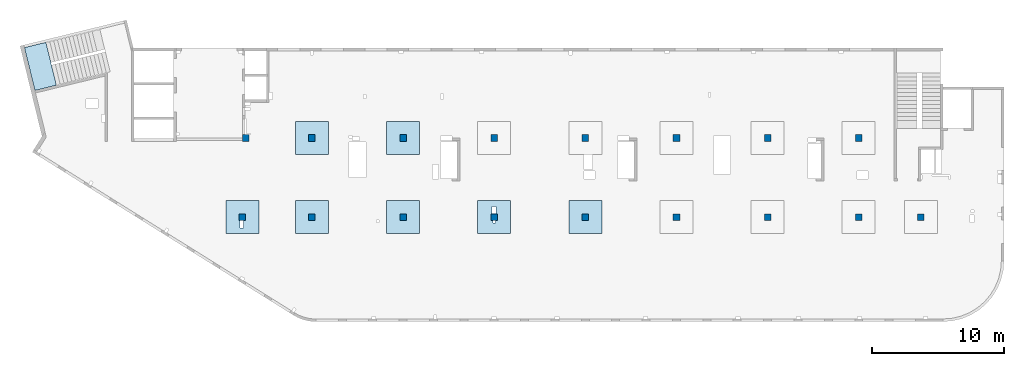
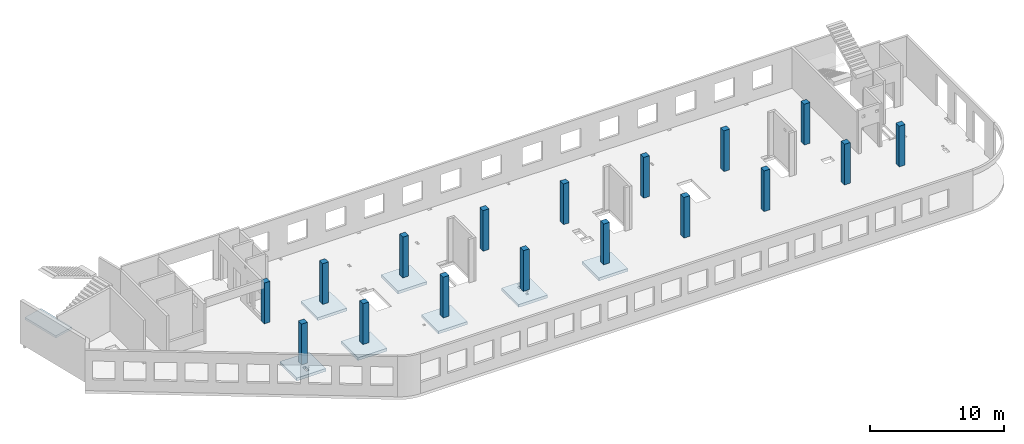
# One storey, part 1 of 7: 17 columns, 8 slabs.
"""IFC4 building model written with IfcOpenShell, lengths in millimetres."""

from ifc_helpers import new_model, entity, si_unit, converted_unit, derived_unit, direction, frame, origin, place, context, subcontext, project, spatial, indexed_curve, outline, extrude, source, transform, mapped, material, type_object, type_shapes, element, save


model = new_model("IFC4")

# Units and contexts
model_context = context("Model", 3, precision=0.01, world=origin(), true_north=direction((6.12303176911189e-17, 1.0)))
plan_context = context("Plan", 3, precision=0.01, world=origin(), true_north=direction((6.12303176911189e-17, 1.0)))
body_context = subcontext(model_context, "Body", "Model", "MODEL_VIEW")
ifc_project = project(units=[si_unit("LENGTHUNIT", "METRE", prefix="MILLI"), si_unit("AREAUNIT", "SQUARE_METRE"), si_unit("VOLUMEUNIT", "CUBIC_METRE"), converted_unit("PLANEANGLEUNIT", "DEGREE", entity("IfcRatioMeasure", 0.0174532925199433), si_unit("PLANEANGLEUNIT", "RADIAN"), dimensions=[0, 0, 0, 0, 0, 0, 0]), si_unit("MASSUNIT", "GRAM", prefix="KILO"), derived_unit("MASSDENSITYUNIT", [(si_unit("MASSUNIT", "GRAM", prefix="KILO"), 1), (si_unit("LENGTHUNIT", "METRE"), -3)]), derived_unit("MOMENTOFINERTIAUNIT", [(si_unit("LENGTHUNIT", "METRE"), 4)]), si_unit("TIMEUNIT", "SECOND"), si_unit("FREQUENCYUNIT", "HERTZ"), si_unit("THERMODYNAMICTEMPERATUREUNIT", "DEGREE_CELSIUS"), derived_unit("THERMALTRANSMITTANCEUNIT", [(si_unit("MASSUNIT", "GRAM", prefix="KILO"), 1), (si_unit("THERMODYNAMICTEMPERATUREUNIT", "KELVIN"), -1), (si_unit("TIMEUNIT", "SECOND"), -3)]), derived_unit("VOLUMETRICFLOWRATEUNIT", [(si_unit("LENGTHUNIT", "METRE"), 3), (si_unit("TIMEUNIT", "SECOND"), -1)]), derived_unit("MASSFLOWRATEUNIT", [(si_unit("MASSUNIT", "GRAM", prefix="KILO"), 1), (si_unit("TIMEUNIT", "SECOND"), -1)]), derived_unit("ROTATIONALFREQUENCYUNIT", [(si_unit("TIMEUNIT", "SECOND"), -1)]), si_unit("ELECTRICCURRENTUNIT", "AMPERE"), si_unit("ELECTRICVOLTAGEUNIT", "VOLT"), si_unit("POWERUNIT", "WATT"), si_unit("FORCEUNIT", "NEWTON", prefix="KILO"), si_unit("ILLUMINANCEUNIT", "LUX"), si_unit("LUMINOUSFLUXUNIT", "LUMEN"), si_unit("LUMINOUSINTENSITYUNIT", "CANDELA"), derived_unit("USERDEFINED", [(si_unit("MASSUNIT", "GRAM", prefix="KILO"), -1), (si_unit("LENGTHUNIT", "METRE"), -2), (si_unit("TIMEUNIT", "SECOND"), 3), (si_unit("LUMINOUSFLUXUNIT", "LUMEN"), 1)]), derived_unit("LINEARVELOCITYUNIT", [(si_unit("LENGTHUNIT", "METRE"), 1), (si_unit("TIMEUNIT", "SECOND"), -1)]), si_unit("PRESSUREUNIT", "PASCAL"), derived_unit("USERDEFINED", [(si_unit("LENGTHUNIT", "METRE"), -2), (si_unit("MASSUNIT", "GRAM", prefix="KILO"), 1), (si_unit("TIMEUNIT", "SECOND"), -2)]), derived_unit("LINEARFORCEUNIT", [(si_unit("MASSUNIT", "GRAM", prefix="KILO"), 1), (si_unit("LENGTHUNIT", "METRE"), 1), (si_unit("TIMEUNIT", "SECOND"), -2), (si_unit("LENGTHUNIT", "METRE"), -1)]), derived_unit("PLANARFORCEUNIT", [(si_unit("MASSUNIT", "GRAM", prefix="KILO"), 1), (si_unit("LENGTHUNIT", "METRE"), 1), (si_unit("TIMEUNIT", "SECOND"), -2), (si_unit("LENGTHUNIT", "METRE"), -2)])], contexts=[model_context, plan_context])

# Site, building, storey
site_placement = place(None, origin())
site = spatial("IfcSite", under=ifc_project, at=site_placement, CompositionType="ELEMENT")
building_placement = place(site_placement, origin())
building = spatial("IfcBuilding", under=site, at=building_placement, CompositionType="ELEMENT")
storey_placement = place(building_placement, frame((0.0, 0.0, 12000.0)))
storey = spatial("IfcBuildingStorey", under=building, at=storey_placement, CompositionType="ELEMENT", Elevation=12000.0)

# Columns
ifc_material = material()
column_type_1 = type_object("IfcColumnType", PredefinedType="COLUMN", material=ifc_material)
shared_shape_1 = source(origin(), body_context, "Body", "SweptSolid", [
    extrude(outline(indexed_curve([(-249.999999999999, -249.999999999999), (250.000000000001, -249.999999999999), (249.999999999999, 249.999999999999), (-250.000000000001, 249.999999999999), (-249.999999999999, -249.999999999999)], self_intersect=False)), frame((15899.9995239258, 7699.99922635584, 11850.0), z_axis=(0.0, 0.0, 1.0), x_axis=(0.0, -1.0, 0.0)), (0.0, 0.0, 1.0), 3700.0),
])
type_shapes(column_type_1, [shared_shape_1])
column_1_placement = place(storey_placement, frame((0.0, 0.0, -12000.0)))
element("IfcColumn", 1, at=column_1_placement, inside=storey, type_object=column_type_1, PredefinedType="COLUMN", context=body_context, shape_type="MappedRepresentation", body=[
    mapped(shared_shape_1, transform((0.0, 0.0, 0.0), scale=1.0)),
])
column_type_2 = type_object("IfcColumnType", PredefinedType="COLUMN", material=ifc_material)
shared_shape_2 = source(origin(), body_context, "Body", "SweptSolid", [
    extrude(outline(indexed_curve([(-249.999999999999, -249.999999999999), (250.000000000001, -249.999999999999), (249.999999999999, 249.999999999999), (-250.000000000001, 249.999999999999), (-249.999999999999, -249.999999999999)], self_intersect=False)), frame((21170.0002685547, 7699.99922635582, 11850.0), z_axis=(0.0, 0.0, 1.0), x_axis=(0.0, -1.0, 0.0)), (0.0, 0.0, 1.0), 3700.0),
])
type_shapes(column_type_2, [shared_shape_2])
column_2_placement = place(storey_placement, frame((0.0, 0.0, -12000.0)))
element("IfcColumn", 2, at=column_2_placement, inside=storey, type_object=column_type_2, PredefinedType="COLUMN", context=body_context, shape_type="MappedRepresentation", body=[
    mapped(shared_shape_2, transform((0.0, 0.0, 0.0), scale=1.0)),
])
column_type_3 = type_object("IfcColumnType", PredefinedType="COLUMN", material=ifc_material)
shared_shape_3 = source(origin(), body_context, "Body", "SweptSolid", [
    extrude(outline(indexed_curve([(-249.999999999999, -249.999999999999), (250.000000000001, -249.999999999999), (250.000000000001, 249.999999999999), (-249.999999999999, 249.999999999999), (-249.999999999999, -249.999999999999)], self_intersect=False)), frame((28070.0002685547, 7699.9992263558, 11850.0), z_axis=(0.0, 0.0, 1.0), x_axis=(0.0, -1.0, 0.0)), (0.0, 0.0, 1.0), 3700.0),
])
type_shapes(column_type_3, [shared_shape_3])
column_3_placement = place(storey_placement, frame((0.0, 0.0, -12000.0)))
element("IfcColumn", 3, at=column_3_placement, inside=storey, type_object=column_type_3, PredefinedType="COLUMN", context=body_context, shape_type="MappedRepresentation", body=[
    mapped(shared_shape_3, transform((0.0, 0.0, 0.0), scale=1.0)),
])
column_type_4 = type_object("IfcColumnType", PredefinedType="COLUMN", material=ifc_material)
shared_shape_4 = source(origin(), body_context, "Body", "SweptSolid", [
    extrude(outline(indexed_curve([(-249.999999999999, -249.999999999999), (250.000000000001, -249.999999999999), (249.999999999999, 249.999999999999), (-250.000000000001, 249.999999999999), (-249.999999999999, -249.999999999999)], self_intersect=False)), frame((34970.0002685547, 7699.99922635577, 11850.0), z_axis=(0.0, 0.0, 1.0), x_axis=(0.0, -1.0, 0.0)), (0.0, 0.0, 1.0), 3700.0),
])
type_shapes(column_type_4, [shared_shape_4])
column_4_placement = place(storey_placement, frame((0.0, 0.0, -12000.0)))
element("IfcColumn", 4, at=column_4_placement, inside=storey, type_object=column_type_4, PredefinedType="COLUMN", context=body_context, shape_type="MappedRepresentation", body=[
    mapped(shared_shape_4, transform((0.0, 0.0, 0.0), scale=1.0)),
])
column_type_5 = type_object("IfcColumnType", PredefinedType="COLUMN", material=ifc_material)
shared_shape_5 = source(origin(), body_context, "Body", "SweptSolid", [
    extrude(outline(indexed_curve([(-249.999999999999, -250.000000000004), (250.000000000001, -250.000000000004), (250.000000000001, 249.999999999995), (-249.999999999999, 250.000000000004), (-249.999999999999, -250.000000000004)], self_intersect=False)), frame((41870.0002685547, 7699.99922635575, 11850.0), z_axis=(0.0, 0.0, 1.0), x_axis=(0.0, -1.0, 0.0)), (0.0, 0.0, 1.0), 3700.0),
])
type_shapes(column_type_5, [shared_shape_5])
column_5_placement = place(storey_placement, frame((0.0, 0.0, -12000.0)))
element("IfcColumn", 5, at=column_5_placement, inside=storey, type_object=column_type_5, PredefinedType="COLUMN", context=body_context, shape_type="MappedRepresentation", body=[
    mapped(shared_shape_5, transform((0.0, 0.0, 0.0), scale=1.0)),
])
column_type_6 = type_object("IfcColumnType", PredefinedType="COLUMN", material=ifc_material)
shared_shape_6 = source(origin(), body_context, "Body", "SweptSolid", [
    extrude(outline(indexed_curve([(-249.999999999999, -250.000000000004), (250.000000000001, -250.000000000004), (249.999999999999, 249.999999999995), (-250.000000000001, 250.000000000004), (-249.999999999999, -250.000000000004)], self_intersect=False)), frame((48770.0002685547, 7699.99922635573, 11850.0), z_axis=(0.0, 0.0, 1.0), x_axis=(0.0, -1.0, 0.0)), (0.0, 0.0, 1.0), 3700.0),
])
type_shapes(column_type_6, [shared_shape_6])
column_6_placement = place(storey_placement, frame((0.0, 0.0, -12000.0)))
element("IfcColumn", 6, at=column_6_placement, inside=storey, type_object=column_type_6, PredefinedType="COLUMN", context=body_context, shape_type="MappedRepresentation", body=[
    mapped(shared_shape_6, transform((0.0, 0.0, 0.0), scale=1.0)),
])
column_type_7 = type_object("IfcColumnType", PredefinedType="COLUMN", material=ifc_material)
shared_shape_7 = source(origin(), body_context, "Body", "SweptSolid", [
    extrude(outline(indexed_curve([(-249.999999999999, -250.000000000004), (250.000000000001, -250.000000000004), (250.000000000001, 249.999999999995), (-249.999999999999, 250.000000000004), (-249.999999999999, -250.000000000004)], self_intersect=False)), frame((55670.0002685547, 7699.99922635571, 11850.0), z_axis=(0.0, 0.0, 1.0), x_axis=(0.0, -1.0, 0.0)), (0.0, 0.0, 1.0), 3700.0),
])
type_shapes(column_type_7, [shared_shape_7])
column_7_placement = place(storey_placement, frame((0.0, 0.0, -12000.0)))
element("IfcColumn", 7, at=column_7_placement, inside=storey, type_object=column_type_7, PredefinedType="COLUMN", context=body_context, shape_type="MappedRepresentation", body=[
    mapped(shared_shape_7, transform((0.0, 0.0, 0.0), scale=1.0)),
])
column_type_8 = type_object("IfcColumnType", PredefinedType="COLUMN", material=ifc_material)
shared_shape_8 = source(origin(), body_context, "Body", "SweptSolid", [
    extrude(outline(indexed_curve([(-249.999999999999, -250.000000000004), (250.000000000001, -250.000000000004), (249.999999999999, 249.999999999995), (-250.000000000001, 250.000000000004), (-249.999999999999, -250.000000000004)], self_intersect=False)), frame((62570.0002685547, 7699.99922635568, 11850.0), z_axis=(0.0, 0.0, 1.0), x_axis=(0.0, -1.0, 0.0)), (0.0, 0.0, 1.0), 3700.0),
])
type_shapes(column_type_8, [shared_shape_8])
column_8_placement = place(storey_placement, frame((0.0, 0.0, -12000.0)))
element("IfcColumn", 8, at=column_8_placement, inside=storey, type_object=column_type_8, PredefinedType="COLUMN", context=body_context, shape_type="MappedRepresentation", body=[
    mapped(shared_shape_8, transform((0.0, 0.0, 0.0), scale=1.0)),
])
column_type_9 = type_object("IfcColumnType", PredefinedType="COLUMN", material=ifc_material)
shared_shape_9 = source(origin(), body_context, "Body", "SweptSolid", [
    extrude(outline(indexed_curve([(-249.999999999999, -250.000000000004), (250.000000000001, -250.000000000004), (249.999999999999, 249.999999999995), (-250.000000000001, 250.000000000004), (-249.999999999999, -250.000000000004)], self_intersect=False)), frame((67270.0002685547, 7699.99922635567, 11850.0), z_axis=(0.0, 0.0, 1.0), x_axis=(0.0, -1.0, 0.0)), (0.0, 0.0, 1.0), 3700.0),
])
type_shapes(column_type_9, [shared_shape_9])
column_9_placement = place(storey_placement, frame((0.0, 0.0, -12000.0)))
element("IfcColumn", 9, at=column_9_placement, inside=storey, type_object=column_type_9, PredefinedType="COLUMN", context=body_context, shape_type="MappedRepresentation", body=[
    mapped(shared_shape_9, transform((0.0, 0.0, 0.0), scale=1.0)),
])
column_type_10 = type_object("IfcColumnType", PredefinedType="COLUMN", material=ifc_material)
shared_shape_10 = source(origin(), body_context, "Body", "SweptSolid", [
    extrude(outline(indexed_curve([(-249.999999999999, -250.000000000004), (249.999999999999, -250.000000000004), (249.999999999999, 249.999999999995), (-249.999999999999, 250.000000000004), (-249.999999999999, -250.000000000004)], self_intersect=False)), frame((62570.0002685547, 13699.9992263555, 11850.0), z_axis=(0.0, 0.0, 1.0), x_axis=(0.0, -1.0, 0.0)), (0.0, 0.0, 1.0), 3700.0),
])
type_shapes(column_type_10, [shared_shape_10])
column_10_placement = place(storey_placement, frame((0.0, 0.0, -12000.0)))
element("IfcColumn", 10, at=column_10_placement, inside=storey, type_object=column_type_10, PredefinedType="COLUMN", context=body_context, shape_type="MappedRepresentation", body=[
    mapped(shared_shape_10, transform((0.0, 0.0, 0.0), scale=1.0)),
])
column_type_11 = type_object("IfcColumnType", PredefinedType="COLUMN", material=ifc_material)
shared_shape_11 = source(origin(), body_context, "Body", "SweptSolid", [
    extrude(outline(indexed_curve([(-249.999999999999, -250.000000000004), (249.999999999999, -250.000000000004), (249.999999999999, 249.999999999995), (-249.999999999999, 250.000000000004), (-249.999999999999, -250.000000000004)], self_intersect=False)), frame((55670.0002685547, 13699.9992263555, 11850.0), z_axis=(0.0, 0.0, 1.0), x_axis=(0.0, -1.0, 0.0)), (0.0, 0.0, 1.0), 3700.0),
])
type_shapes(column_type_11, [shared_shape_11])
column_11_placement = place(storey_placement, frame((0.0, 0.0, -12000.0)))
element("IfcColumn", 11, at=column_11_placement, inside=storey, type_object=column_type_11, PredefinedType="COLUMN", context=body_context, shape_type="MappedRepresentation", body=[
    mapped(shared_shape_11, transform((0.0, 0.0, 0.0), scale=1.0)),
])
column_type_12 = type_object("IfcColumnType", PredefinedType="COLUMN", material=ifc_material)
shared_shape_12 = source(origin(), body_context, "Body", "SweptSolid", [
    extrude(outline(indexed_curve([(-249.999999999999, -250.000000000004), (249.999999999999, -250.000000000004), (249.999999999999, 249.999999999995), (-249.999999999999, 250.000000000004), (-249.999999999999, -250.000000000004)], self_intersect=False)), frame((48770.0002685547, 13699.9992263556, 11850.0), z_axis=(0.0, 0.0, 1.0), x_axis=(0.0, -1.0, 0.0)), (0.0, 0.0, 1.0), 3700.0),
])
type_shapes(column_type_12, [shared_shape_12])
column_12_placement = place(storey_placement, frame((0.0, 0.0, -12000.0)))
element("IfcColumn", 12, at=column_12_placement, inside=storey, type_object=column_type_12, PredefinedType="COLUMN", context=body_context, shape_type="MappedRepresentation", body=[
    mapped(shared_shape_12, transform((0.0, 0.0, 0.0), scale=1.0)),
])
column_type_13 = type_object("IfcColumnType", PredefinedType="COLUMN", material=ifc_material)
shared_shape_13 = source(origin(), body_context, "Body", "SweptSolid", [
    extrude(outline(indexed_curve([(-249.999999999999, -250.000000000004), (249.999999999999, -250.000000000004), (249.999999999999, 249.999999999995), (-249.999999999999, 250.000000000004), (-249.999999999999, -250.000000000004)], self_intersect=False)), frame((41870.0002685547, 13699.9992263556, 11850.0), z_axis=(0.0, 0.0, 1.0), x_axis=(0.0, -1.0, 0.0)), (0.0, 0.0, 1.0), 3700.0),
])
type_shapes(column_type_13, [shared_shape_13])
column_13_placement = place(storey_placement, frame((0.0, 0.0, -12000.0)))
element("IfcColumn", 13, at=column_13_placement, inside=storey, type_object=column_type_13, PredefinedType="COLUMN", context=body_context, shape_type="MappedRepresentation", body=[
    mapped(shared_shape_13, transform((0.0, 0.0, 0.0), scale=1.0)),
])
column_type_14 = type_object("IfcColumnType", PredefinedType="COLUMN", material=ifc_material)
shared_shape_14 = source(origin(), body_context, "Body", "SweptSolid", [
    extrude(outline(indexed_curve([(-249.999999999999, -249.999999999999), (249.999999999999, -249.999999999999), (249.999999999999, 249.999999999999), (-249.999999999999, 249.999999999999), (-249.999999999999, -249.999999999999)], self_intersect=False)), frame((34970.0002685547, 13699.9992263556, 11850.0), z_axis=(0.0, 0.0, 1.0), x_axis=(0.0, -1.0, 0.0)), (0.0, 0.0, 1.0), 3700.0),
])
type_shapes(column_type_14, [shared_shape_14])
column_14_placement = place(storey_placement, frame((0.0, 0.0, -12000.0)))
element("IfcColumn", 14, at=column_14_placement, inside=storey, type_object=column_type_14, PredefinedType="COLUMN", context=body_context, shape_type="MappedRepresentation", body=[
    mapped(shared_shape_14, transform((0.0, 0.0, 0.0), scale=1.0)),
])
column_type_15 = type_object("IfcColumnType", PredefinedType="COLUMN", material=ifc_material)
shared_shape_15 = source(origin(), body_context, "Body", "SweptSolid", [
    extrude(outline(indexed_curve([(-249.999999999999, -249.999999999999), (249.999999999999, -249.999999999999), (249.999999999999, 249.999999999999), (-249.999999999999, 249.999999999999), (-249.999999999999, -249.999999999999)], self_intersect=False)), frame((28070.0002685547, 13699.9992263556, 11850.0), z_axis=(0.0, 0.0, 1.0), x_axis=(0.0, -1.0, 0.0)), (0.0, 0.0, 1.0), 3700.0),
])
type_shapes(column_type_15, [shared_shape_15])
column_15_placement = place(storey_placement, frame((0.0, 0.0, -12000.0)))
element("IfcColumn", 15, at=column_15_placement, inside=storey, type_object=column_type_15, PredefinedType="COLUMN", context=body_context, shape_type="MappedRepresentation", body=[
    mapped(shared_shape_15, transform((0.0, 0.0, 0.0), scale=1.0)),
])
column_type_16 = type_object("IfcColumnType", PredefinedType="COLUMN", material=ifc_material)
shared_shape_16 = source(origin(), body_context, "Body", "SweptSolid", [
    extrude(outline(indexed_curve([(-249.999999999999, -249.999999999999), (249.999999999999, -249.999999999999), (249.999999999999, 249.999999999999), (-249.999999999999, 249.999999999999), (-249.999999999999, -249.999999999999)], self_intersect=False)), frame((21170.0002685547, 13699.9992263556, 11850.0), z_axis=(0.0, 0.0, 1.0), x_axis=(0.0, -1.0, 0.0)), (0.0, 0.0, 1.0), 3700.0),
])
type_shapes(column_type_16, [shared_shape_16])
column_16_placement = place(storey_placement, frame((0.0, 0.0, -12000.0)))
element("IfcColumn", 16, at=column_16_placement, inside=storey, type_object=column_type_16, PredefinedType="COLUMN", context=body_context, shape_type="MappedRepresentation", body=[
    mapped(shared_shape_16, transform((0.0, 0.0, 0.0), scale=1.0)),
])
column_type_17 = type_object("IfcColumnType", PredefinedType="COLUMN", material=ifc_material)
shared_shape_17 = source(origin(), body_context, "Body", "SweptSolid", [
    extrude(outline(indexed_curve([(-249.999999999999, -249.999999999999), (249.999999999999, -249.999999999999), (249.999999999999, 249.999999999999), (-249.999999999999, 249.999999999999), (-249.999999999999, -249.999999999999)], self_intersect=False)), frame((16160.0002685547, 13699.9992263558, 11850.0), z_axis=(0.0, 0.0, 1.0), x_axis=(0.0, -1.0, 0.0)), (0.0, 0.0, 1.0), 3700.0),
])
type_shapes(column_type_17, [shared_shape_17])
column_17_placement = place(storey_placement, frame((0.0, 0.0, -12000.0)))
element("IfcColumn", 17, at=column_17_placement, inside=storey, type_object=column_type_17, PredefinedType="COLUMN", context=body_context, shape_type="MappedRepresentation", body=[
    mapped(shared_shape_17, transform((0.0, 0.0, 0.0), scale=1.0)),
])

# Slabs
slab_type_1 = type_object("IfcSlabType", PredefinedType="FLOOR", material=ifc_material)
slab_1_placement = place(storey_placement, origin())
element("IfcSlab", 18, at=slab_1_placement, inside=storey, type_object=slab_type_1, material=ifc_material, PredefinedType="FLOOR", context=body_context, shape_type="SweptSolid", body=[
    extrude(outline(indexed_curve([(-999.999999999999, -1250.0), (1500.0, -1250.0), (1500.0, 1250.0), (-999.999999999999, 1250.0), (-1000.0, -1.73258740687743e-12), (-999.999999999999, -1250.0)], self_intersect=False), holes=[indexed_curve([(500.000000000006, 89.9999999999999), (1060.0, 90.0000000000009), (1060.0, -159.999999999999), (500.000000000007, -160.0), (500.000000000006, 89.9999999999999)], self_intersect=False)]), frame((15900.0002685547, 7949.99922635584, -650.0), z_axis=(0.0, 0.0, 1.0), x_axis=(0.0, -1.0, 0.0)), (0.0, 0.0, 1.0), 249.999999999999),
])
slab_type_2 = type_object("IfcSlabType", PredefinedType="FLOOR", material=ifc_material)
slab_2_placement = place(storey_placement, origin())
element("IfcSlab", 19, at=slab_2_placement, inside=storey, type_object=slab_type_2, material=ifc_material, PredefinedType="FLOOR", context=body_context, shape_type="SweptSolid", body=[
    extrude(outline(indexed_curve([(-1250.0, -1250.0), (1250.0, -1250.0), (1250.0, 1250.0), (-1250.0, 1250.0), (-1250.0, -1250.0)], self_intersect=False)), frame((21170.0002685547, 7699.99922635582, -400.0), z_axis=(0.0, 0.0, -1.0), x_axis=(0.0, 1.0, 0.0)), (0.0, 0.0, 1.0), 249.999999999999),
])
slab_type_3 = type_object("IfcSlabType", PredefinedType="FLOOR", material=ifc_material)
slab_3_placement = place(storey_placement, origin())
element("IfcSlab", 20, at=slab_3_placement, inside=storey, type_object=slab_type_3, material=ifc_material, PredefinedType="FLOOR", context=body_context, shape_type="SweptSolid", body=[
    extrude(outline(indexed_curve([(-1250.0, -1250.0), (1250.0, -1250.0), (1250.0, 1250.0), (-1250.0, 1250.0), (-1250.0, -1250.0)], self_intersect=False)), frame((28070.0002685547, 7699.9992263558, -400.0), z_axis=(0.0, 0.0, -1.0), x_axis=(0.0, 1.0, 0.0)), (0.0, 0.0, 1.0), 249.999999999999),
])
slab_type_4 = type_object("IfcSlabType", PredefinedType="FLOOR", material=ifc_material)
slab_4_placement = place(storey_placement, origin())
element("IfcSlab", 21, at=slab_4_placement, inside=storey, type_object=slab_type_4, material=ifc_material, PredefinedType="FLOOR", context=body_context, shape_type="SweptSolid", body=[
    extrude(outline(indexed_curve([(-999.999999999999, -1250.00000000001), (1500.0, -1250.00000000001), (1500.0, 1250.0), (-999.999999999999, 1250.0), (-1000.0, -6.064055924071e-12), (-999.999999999999, -1250.00000000001)], self_intersect=False), holes=[indexed_curve([(500.000000000073, 99.9999999999998), (700.000000000076, 100.0), (700.000000000076, -100.000000000002), (500.000000000074, -100.000000000002), (500.000000000073, 99.9999999999998)], self_intersect=False), indexed_curve([(-549.999999999928, 149.999999999991), (-39.9999999999262, 149.999999999992), (-39.9999999999256, -180.000000000007), (-549.999999999928, -180.000000000008), (-549.999999999928, 149.999999999991)], self_intersect=False)]), frame((34970.0002685547, 7949.99922635578, -650.0), z_axis=(0.0, 0.0, 1.0), x_axis=(0.0, -1.0, 0.0)), (0.0, 0.0, 1.0), 249.999999999999),
])
slab_type_5 = type_object("IfcSlabType", PredefinedType="FLOOR", material=ifc_material)
slab_5_placement = place(storey_placement, origin())
element("IfcSlab", 22, at=slab_5_placement, inside=storey, type_object=slab_type_5, material=ifc_material, PredefinedType="FLOOR", context=body_context, shape_type="SweptSolid", body=[
    extrude(outline(indexed_curve([(-1250.0, -1250.0), (1250.0, -1250.0), (1250.0, 1250.0), (-1250.0, 1250.0), (-1250.0, -1250.0)], self_intersect=False)), frame((41870.0002685547, 7699.99922635575, -400.0), z_axis=(0.0, 0.0, -1.0), x_axis=(0.0, 1.0, 0.0)), (0.0, 0.0, 1.0), 249.999999999999),
])
slab_type_6 = type_object("IfcSlabType", PredefinedType="FLOOR", material=ifc_material)
slab_6_placement = place(storey_placement, origin())
element("IfcSlab", 23, at=slab_6_placement, inside=storey, type_object=slab_type_6, material=ifc_material, PredefinedType="FLOOR", context=body_context, shape_type="SweptSolid", body=[
    extrude(outline(indexed_curve([(-1250.0, -1250.0), (1250.0, -1250.0), (1250.0, 1250.0), (-1250.0, 1250.0), (-1250.0, -1250.0)], self_intersect=False)), frame((28070.0002685547, 13699.9992263556, -400.0), z_axis=(0.0, 0.0, -1.0), x_axis=(0.0, 1.0, 0.0)), (0.0, 0.0, 1.0), 249.999999999999),
])
slab_type_7 = type_object("IfcSlabType", PredefinedType="FLOOR", material=ifc_material)
slab_7_placement = place(storey_placement, origin())
element("IfcSlab", 24, at=slab_7_placement, inside=storey, type_object=slab_type_7, material=ifc_material, PredefinedType="FLOOR", context=body_context, shape_type="SweptSolid", body=[
    extrude(outline(indexed_curve([(-1250.0, -1250.0), (1250.0, -1250.0), (1250.0, 1250.0), (-1250.0, 1250.0), (-1250.0, -1250.0)], self_intersect=False)), frame((21170.0002685547, 13699.9992263556, -400.0), z_axis=(0.0, 0.0, -1.0), x_axis=(0.0, 1.0, 0.0)), (0.0, 0.0, 1.0), 249.999999999999),
])
slab_type_8 = type_object("IfcSlabType", PredefinedType="FLOOR", material=ifc_material)
slab_8_placement = place(storey_placement, origin())
element("IfcSlab", 25, at=slab_8_placement, inside=storey, type_object=slab_type_8, material=ifc_material, PredefinedType="FLOOR", context=body_context, shape_type="SweptSolid", body=[
    extrude(outline(indexed_curve([(-835.0, -1670.00000000002), (835.0, -1670.00000000002), (835.0, 1670.00000000002), (-835.000000000001, 1670.00000000002), (-835.0, -1670.00000000002)], self_intersect=False)), frame((612.299389166834, 19119.7750964545, 1920.0), z_axis=(0.0, 0.0, -1.0), x_axis=(0.971552058141474, 0.236826092990333, 0.0)), (0.0, 0.0, 1.0), 200.0),
])

save(model, "model.ifc")
